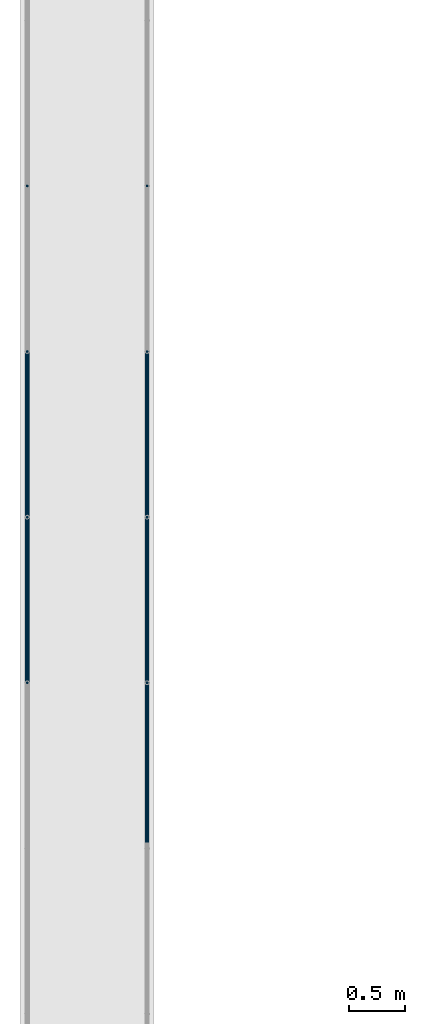
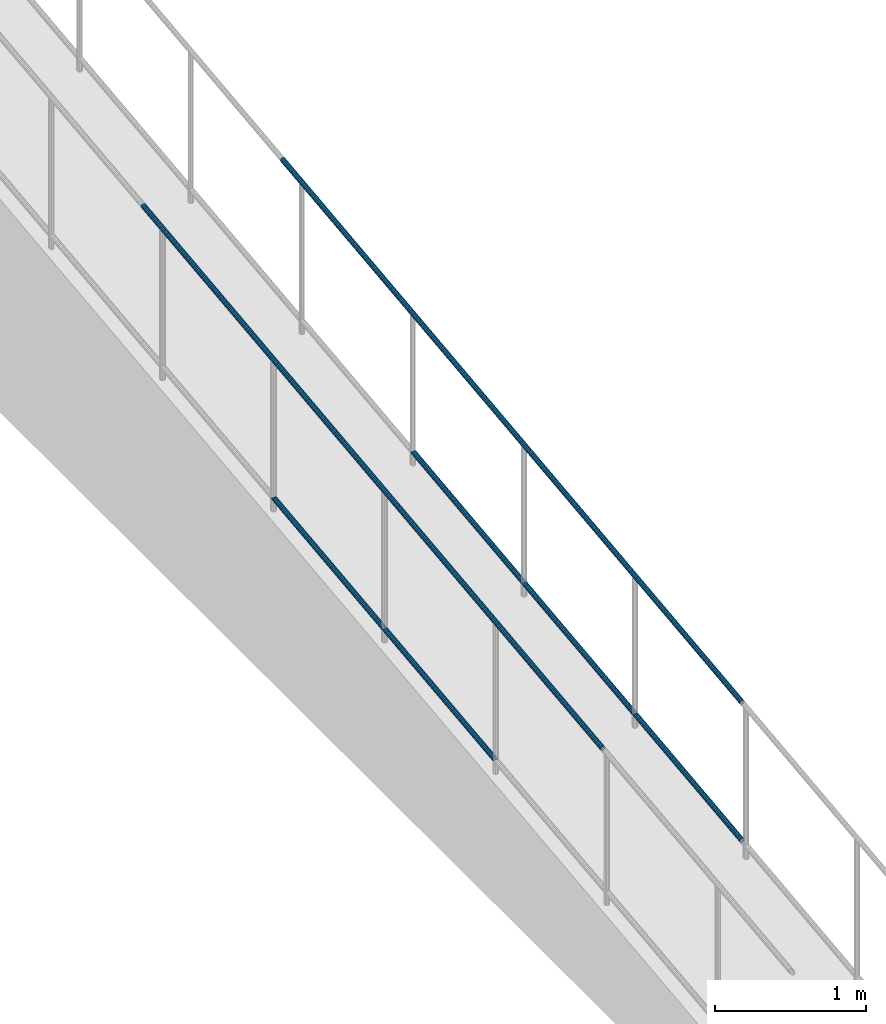
# One storey, part 1034 of 1763: 7 beams, 2 elements without a shape of their own.
"""IFC2X3 building model written with IfcOpenShell, lengths in millimetres."""

from ifc_helpers import new_model, si_unit, frame, origin_with_axes, place, context, subcontext, project, spatial, faceted_brep, material, type_object, element, aggregate, save


model = new_model("IFC2X3")

# Units and contexts
model_context = context("Model", 3, precision=1e-05, world=origin_with_axes())
body_context = subcontext(model_context, "Body", "Model", "MODEL_VIEW")
ifc_project = project(units=[si_unit("LENGTHUNIT", "METRE", prefix="MILLI"), si_unit("AREAUNIT", "SQUARE_METRE"), si_unit("VOLUMEUNIT", "CUBIC_METRE"), si_unit("MASSUNIT", "GRAM", prefix="KILO"), si_unit("TIMEUNIT", "SECOND"), si_unit("PLANEANGLEUNIT", "RADIAN"), si_unit("SOLIDANGLEUNIT", "STERADIAN"), si_unit("THERMODYNAMICTEMPERATUREUNIT", "DEGREE_CELSIUS"), si_unit("LUMINOUSINTENSITYUNIT", "LUMEN")], contexts=[model_context])

# Site, building, storey
site_placement = place(None, origin_with_axes())
site = spatial("IfcSite", under=ifc_project, at=site_placement, CompositionType="ELEMENT")
building_placement = place(site_placement, origin_with_axes())
building = spatial("IfcBuilding", under=site, at=building_placement, Name="Undefined", CompositionType="ELEMENT")
storey_placement = place(building_placement, origin_with_axes())
storey = spatial("IfcBuildingStorey", under=building, at=storey_placement, Name="Undefined", CompositionType="ELEMENT", Elevation=0.0)

# Assembly, beams
assembly_1_placement = place(storey_placement, origin_with_axes())
assembly_1 = element("IfcElementAssembly", 1, at=assembly_1_placement, inside=storey, Name="GUARDRAIL", AssemblyPlace="NOTDEFINED", PredefinedType="RIGID_FRAME")
ifc_material = material(Name="STEEL/A513")
beam_type = type_object("IfcBeamType", PredefinedType="NOTDEFINED")
beam_1_placement = place(assembly_1_placement, frame((-97200.6527017878, -5416.76211461858, 4661.28961246358), z_axis=(0.0, -0.114062593029902, 0.993473565260443), x_axis=(0.0, 0.993473565260443, 0.114062593029902)))
beam_1 = element("IfcBeam", 2, at=beam_1_placement, type_object=beam_type, material=ifc_material, Name="GUARDRAIL", context=body_context, shape_type="Brep", body=[
    faceted_brep([(1468.16665642951, -9.52499999999418, 16.4977839425555), (1467.58900470802, -9.52499999999418, 11.4667123804174), (1467.30376971339, -7.68349999999919, 13.3082123804179), (1465.46783960526, 0.0, 15.3670000004613), (1465.89071001447, 0.0, 19.0500000004622), (1467.3037697134, 7.68349999999919, 13.308212380417), (1467.58900470802, 9.52499999999418, 11.4667123804174), (1468.16665642951, 9.52499999999418, 16.4977839425555), (1482.87860532686, 19.0500000000029, 4.66570782009512e-10), (1474.38465767071, 16.4977839420899, 9.52500000046439), (1472.19739693342, 16.4977839420899, -9.52499999953761), (1470.96269582906, 13.3082123799541, 7.68350000046303), (1472.15281425492, 15.3669999999984, 4.6293280320242e-10), (1469.19830550098, 13.3082123799541, -7.68349999953807), (1464.95586142462, 9.52499999999418, -11.4667123794952), (1464.37820970313, 9.52499999999418, -16.4977839416342), (1464.24775602078, 7.68349999999919, -13.3082123794957), (1461.9390589491, 0.0, -15.3669999995409), (1461.51618853989, 0.0, -19.0499999995409), (1464.95586142462, -9.52499999999418, -11.4667123794952), (1464.37820970313, -9.52499999999418, -16.4977839416342), (1464.24775602078, -7.68349999999919, -13.3082123794948), (1482.87860532695, -19.0500000000029, 4.55656845588237e-10), (1472.19739693342, -16.4977839420899, -9.52499999953761), (1474.38465767071, -16.4977839420899, 9.52500000046439), (1469.19830550097, -13.3082123799541, -7.68349999953807), (1472.15281425491, -15.3669999999984, 4.6293280320242e-10), (1470.96269582905, -13.3082123799541, 7.68350000046303), (8.49463121237, -16.4977839420899, -9.52499999999782), (14.7126324911599, -9.52499999999418, -16.4977839420899), (0.00068350478454704, 19.0500000000029, 0.0), (8.49463121237, 16.4977839420899, -9.52499999999782), (10.6818918337324, 16.4977839420899, 9.52500000000418), (18.5010790167537, 9.52499999999418, 16.4977839421008), (21.3631001626848, 0.0, 19.0500000000075), (14.7126324911599, 9.52499999999418, -16.4977839420899), (16.9885789199607, 0.0, -19.0499999999956), (17.4114493067575, 0.0, -15.3669999999956), (15.2902841820321, -9.52499999999418, -11.4667123799509), (15.575519187561, -7.68349999999919, -13.3082123799513), (15.575519187561, 7.68349999999919, -13.3082123799513), (15.2902841820321, 9.52499999999418, -11.4667123799509), (11.9165930406441, 13.3082123799541, -7.68349999999646), (10.7264745694495, 15.3669999999984, 4.54747350886464e-12), (13.6809832752053, 13.3082123799541, 7.68350000000555), (17.923427325881, 9.52499999999418, 11.4667123799609), (18.631532718199, 7.68349999999919, 13.3082123799622), (20.9402297758882, 0.0, 15.3670000000075), (18.631532718199, -7.68349999999919, 13.3082123799622), (17.923427325881, -9.52499999999418, 11.4667123799609), (18.5010790167537, -9.52499999999418, 16.4977839421008), (10.6818918337324, -16.4977839420899, 9.52500000000418), (0.00068350478454704, -19.0500000000029, 0.0), (13.6809832752053, -13.3082123799541, 7.68350000000555), (10.7264745694495, -15.3669999999984, 4.54747350886464e-12), (11.9165930406441, -13.3082123799541, -7.68349999999646)], [[[0, 1, 2, 3, 4]], [[4, 3, 5, 6, 7]], [[8, 9, 10]], [[7, 6, 11, 12, 13, 14, 15, 10, 9]], [[16, 17, 18, 15, 14]], [[19, 20, 18, 17, 21]], [[22, 23, 24]], [[24, 23, 20, 19, 25, 26, 27, 1, 0]], [[28, 29, 20, 23]], [[30, 31, 32]], [[33, 34, 4, 7]], [[32, 33, 7, 9]], [[30, 32, 9, 8]], [[31, 30, 8, 10]], [[35, 31, 10, 15]], [[36, 35, 15, 18]], [[29, 36, 18, 20]], [[37, 36, 29, 38, 39]], [[40, 41, 35, 36, 37]], [[32, 31, 35, 41, 42, 43, 44, 45, 33]], [[33, 45, 46, 47, 34]], [[34, 47, 48, 49, 50]], [[34, 50, 0, 4]], [[50, 51, 24, 0]], [[51, 52, 22, 24]], [[52, 28, 23, 22]], [[51, 28, 52]], [[50, 49, 53, 54, 55, 38, 29, 28, 51]], [[55, 54, 26, 25]], [[21, 39, 38, 55, 25, 19]], [[37, 39, 21, 17]], [[40, 37, 17, 16]], [[42, 41, 40, 16, 14, 13]], [[43, 42, 13, 12]], [[44, 43, 12, 11]], [[5, 46, 45, 44, 11, 6]], [[47, 46, 5, 3]], [[48, 47, 3, 2]], [[53, 49, 48, 2, 1, 27]], [[54, 53, 27, 26]]]),
])
beam_2_placement = place(assembly_1_placement, frame((-97200.6527017878, -6889.96211609653, 4492.14871320254), z_axis=(0.0, -0.114062593029902, 0.993473565260443), x_axis=(0.0, 0.993473565260443, 0.114062593029902)))
beam_2 = element("IfcBeam", 3, at=beam_2_placement, type_object=beam_type, material=ifc_material, Name="GUARDRAIL", context=body_context, shape_type="Brep", body=[
    faceted_brep([(1468.16665642951, -9.52499999999418, 16.4977839425555), (1467.58900470802, -9.52499999999418, 11.4667123804174), (1467.30376971339, -7.68349999999919, 13.3082123804179), (1465.46783960526, 0.0, 15.3670000004613), (1465.89071001447, 0.0, 19.0500000004622), (1467.3037697134, 7.68349999999919, 13.308212380417), (1467.58900470802, 9.52499999999418, 11.4667123804174), (1468.16665642951, 9.52499999999418, 16.4977839425555), (1482.87860532686, 19.0500000000029, 4.66570782009512e-10), (1474.38465767071, 16.4977839420899, 9.52500000046439), (1472.19739693342, 16.4977839420899, -9.52499999953761), (1470.96269582906, 13.3082123799541, 7.68350000046303), (1472.15281425492, 15.3669999999984, 4.6293280320242e-10), (1469.19830550098, 13.3082123799541, -7.68349999953807), (1464.95586142462, 9.52499999999418, -11.4667123794952), (1464.37820970313, 9.52499999999418, -16.4977839416342), (1464.24775602078, 7.68349999999919, -13.3082123794957), (1461.9390589491, 0.0, -15.3669999995409), (1461.51618853989, 0.0, -19.0499999995409), (1464.95586142462, -9.52499999999418, -11.4667123794952), (1464.37820970313, -9.52499999999418, -16.4977839416342), (1464.24775602078, -7.68349999999919, -13.3082123794948), (1482.87860532695, -19.0500000000029, 4.55656845588237e-10), (1472.19739693342, -16.4977839420899, -9.52499999953761), (1474.38465767071, -16.4977839420899, 9.52500000046439), (1469.19830550097, -13.3082123799541, -7.68349999953807), (1472.15281425491, -15.3669999999984, 4.6293280320242e-10), (1470.96269582905, -13.3082123799541, 7.68350000046303), (8.49463121237, -16.4977839420899, -9.52499999999782), (14.7126324911599, -9.52499999999418, -16.4977839420899), (0.00068350478454704, 19.0500000000029, 0.0), (8.49463121237, 16.4977839420899, -9.52499999999782), (10.6818918337324, 16.4977839420899, 9.52500000000418), (18.5010790167537, 9.52499999999418, 16.4977839421008), (21.3631001626848, 0.0, 19.0500000000075), (14.7126324911599, 9.52499999999418, -16.4977839420899), (16.9885789199607, 0.0, -19.0499999999956), (17.4114493067575, 0.0, -15.3669999999956), (15.2902841820321, -9.52499999999418, -11.4667123799509), (15.575519187561, -7.68349999999919, -13.3082123799513), (15.575519187561, 7.68349999999919, -13.3082123799513), (15.2902841820321, 9.52499999999418, -11.4667123799509), (11.9165930406441, 13.3082123799541, -7.68349999999646), (10.7264745694495, 15.3669999999984, 4.54747350886464e-12), (13.6809832752053, 13.3082123799541, 7.68350000000555), (17.923427325881, 9.52499999999418, 11.4667123799609), (18.631532718199, 7.68349999999919, 13.3082123799622), (20.9402297758882, 0.0, 15.3670000000075), (18.631532718199, -7.68349999999919, 13.3082123799622), (17.923427325881, -9.52499999999418, 11.4667123799609), (18.5010790167537, -9.52499999999418, 16.4977839421008), (10.6818918337324, -16.4977839420899, 9.52500000000418), (0.00068350478454704, -19.0500000000029, 0.0), (13.6809832752053, -13.3082123799541, 7.68350000000555), (10.7264745694495, -15.3669999999984, 4.54747350886464e-12), (11.9165930406441, -13.3082123799541, -7.68349999999646)], [[[0, 1, 2, 3, 4]], [[4, 3, 5, 6, 7]], [[8, 9, 10]], [[7, 6, 11, 12, 13, 14, 15, 10, 9]], [[16, 17, 18, 15, 14]], [[19, 20, 18, 17, 21]], [[22, 23, 24]], [[24, 23, 20, 19, 25, 26, 27, 1, 0]], [[28, 29, 20, 23]], [[30, 31, 32]], [[33, 34, 4, 7]], [[32, 33, 7, 9]], [[30, 32, 9, 8]], [[31, 30, 8, 10]], [[35, 31, 10, 15]], [[36, 35, 15, 18]], [[29, 36, 18, 20]], [[37, 36, 29, 38, 39]], [[40, 41, 35, 36, 37]], [[32, 31, 35, 41, 42, 43, 44, 45, 33]], [[33, 45, 46, 47, 34]], [[34, 47, 48, 49, 50]], [[34, 50, 0, 4]], [[50, 51, 24, 0]], [[51, 52, 22, 24]], [[52, 28, 23, 22]], [[51, 28, 52]], [[50, 49, 53, 54, 55, 38, 29, 28, 51]], [[55, 54, 26, 25]], [[21, 39, 38, 55, 25, 19]], [[37, 39, 21, 17]], [[40, 37, 17, 16]], [[42, 41, 40, 16, 14, 13]], [[43, 42, 13, 12]], [[44, 43, 12, 11]], [[5, 46, 45, 44, 11, 6]], [[47, 46, 5, 3]], [[48, 47, 3, 2]], [[53, 49, 48, 2, 1, 27]], [[54, 53, 27, 26]]]),
])
beam_3_placement = place(assembly_1_placement, frame((-97200.6527017878, -2216.29390356327, 6146.34146606881), z_axis=(1.0, 0.0, 0.0), x_axis=(0.0, -0.993473565260443, -0.114062593029902)))
beam_3 = element("IfcBeam", 4, at=beam_3_placement, type_object=beam_type, material=ifc_material, Name="GUARDRAIL", context=body_context, shape_type="Brep", body=[
    faceted_brep([(4.71409293822944e-08, -15.3669999999984, 0.0), (-1.81898940354586e-12, -13.3082123799541, 7.68349999999919), (6136.046507088, -13.3082123818076, 7.68349999999919), (6136.046507088, -15.3670000018528, 0.0), (-3.63797880709171e-12, -7.68349999999919, 13.3082123799531), (6136.046507088, -7.68350000185274, 13.3082123799541), (-1.81898940354586e-12, 0.0, 15.3669999999966), (6136.046507088, -1.85082171810791e-09, 15.3669999999984), (-3.63797880709171e-12, 7.68349999999919, 13.3082123799531), (6136.046507088, 7.68349999814836, 13.3082123799541), (-1.81898940354586e-12, 13.3082123799541, 7.68349999999919), (6136.046507088, 13.3082123781051, 7.68349999999919), (4.71409293822944e-08, 15.3669999999984, 0.0), (6136.046507088, 15.3669999981494, 0.0), (3.63797880709171e-12, 13.3082123799541, -7.68349999999737), (6136.046507088, 13.3082123781051, -7.68349999999919), (3.63797880709171e-12, 7.68349999999919, -13.3082123799522), (6136.046507088, 7.68349999814836, -13.3082123799541), (3.63797880709171e-12, 0.0, -15.3669999999956), (6136.046507088, -1.85082171810791e-09, -15.3669999999984), (3.63797880709171e-12, -7.68349999999919, -13.3082123799522), (6136.046507088, -7.68350000185274, -13.3082123799541), (3.63797880709171e-12, -13.3082123799541, -7.68349999999737), (6136.046507088, -13.3082123818076, -7.68349999999919), (0.0, -19.0500000000029, 0.0), (0.0, -16.4977839420899, -9.52500000000146), (6136.046507088, -16.4977839439462, -9.52499999999418), (6136.046507088, -19.0500000018519, 0.0), (0.0, -9.52499999999418, -16.4977839420935), (6136.046507088, -9.52500000185228, -16.4977839420899), (1.45519152283669e-11, 1.81898940354586e-12, -19.0499999999993), (6136.046507088, -1.85082171810791e-09, -19.0500000000029), (0.0, 9.52499999999418, -16.4977839420935), (6136.046507088, 9.5249999981479, -16.4977839420899), (0.0, 16.4977839420899, -9.52500000000146), (6136.046507088, 16.4977839402427, -9.52499999999418), (0.0, 19.0500000000029, 0.0), (6136.046507088, 19.0499999981485, 0.0), (0.0, 16.4977839420899, 9.52500000000146), (6136.046507088, 16.4977839402427, 9.52499999999418), (0.0, 9.52499999999418, 16.4977839420935), (6136.046507088, 9.5249999981479, 16.4977839420899), (1.45519152283669e-11, 1.81898940354586e-12, 19.0499999999993), (6136.046507088, -1.85082171810791e-09, 19.0500000000029), (0.0, -9.52499999999418, 16.4977839420935), (6136.046507088, -9.52500000185228, 16.4977839420899), (0.0, -16.4977839420899, 9.52500000000146), (6136.046507088, -16.4977839439462, 9.52499999999418)], [[[0, 1, 2, 3]], [[1, 4, 5, 2]], [[4, 6, 7, 5]], [[6, 8, 9, 7]], [[8, 10, 11, 9]], [[10, 12, 13, 11]], [[12, 14, 15, 13]], [[14, 16, 17, 15]], [[16, 18, 19, 17]], [[18, 20, 21, 19]], [[20, 22, 23, 21]], [[22, 0, 3, 23]], [[24, 25, 26, 27]], [[25, 28, 29, 26]], [[28, 30, 31, 29]], [[30, 32, 33, 31]], [[32, 34, 35, 33]], [[34, 36, 37, 35]], [[36, 38, 39, 37]], [[38, 40, 41, 39]], [[40, 42, 43, 41]], [[42, 44, 45, 43]], [[44, 46, 47, 45]], [[46, 24, 27, 47]], [[29, 31, 33, 35, 37, 39, 41, 43, 45, 47, 27, 26], [5, 7, 9, 11, 13, 15, 17, 19, 21, 23, 3, 2]], [[46, 44, 42, 40, 38, 36, 34, 32, 30, 28, 25, 24], [22, 20, 18, 16, 14, 12, 10, 8, 6, 4, 1, 0]]]),
])
aggregate(assembly_1, [beam_1, beam_2, beam_3])

assembly_2_placement = place(storey_placement, origin_with_axes())
assembly_2 = element("IfcElementAssembly", 5, at=assembly_2_placement, inside=storey, Name="GUARDRAIL", AssemblyPlace="NOTDEFINED", PredefinedType="RIGID_FRAME")
beam_4_placement = place(assembly_2_placement, frame((-96133.8527017878, -2216.29390356327, 6146.34146606881), z_axis=(1.0, 0.0, 0.0), x_axis=(0.0, -0.993473565260443, -0.114062593029902)))
beam_4 = element("IfcBeam", 6, at=beam_4_placement, type_object=beam_type, material=ifc_material, Name="GUARDRAIL", context=body_context, shape_type="Brep", body=[
    faceted_brep([(4.71409293822944e-08, -15.3669999999984, 0.0), (-1.81898940354586e-12, -13.3082123799541, 7.68349999999919), (6136.046507088, -13.3082123818076, 7.68349999999919), (6136.046507088, -15.3670000018528, 0.0), (-3.63797880709171e-12, -7.68349999999919, 13.3082123799531), (6136.046507088, -7.68350000185274, 13.3082123799541), (-1.81898940354586e-12, 0.0, 15.3669999999966), (6136.046507088, -1.85082171810791e-09, 15.3669999999984), (-3.63797880709171e-12, 7.68349999999919, 13.3082123799531), (6136.046507088, 7.68349999814836, 13.3082123799541), (-1.81898940354586e-12, 13.3082123799541, 7.68349999999919), (6136.046507088, 13.3082123781051, 7.68349999999919), (4.71409293822944e-08, 15.3669999999984, 0.0), (6136.046507088, 15.3669999981494, 0.0), (3.63797880709171e-12, 13.3082123799541, -7.68349999999737), (6136.046507088, 13.3082123781051, -7.68349999999919), (3.63797880709171e-12, 7.68349999999919, -13.3082123799522), (6136.046507088, 7.68349999814836, -13.3082123799541), (3.63797880709171e-12, 0.0, -15.3669999999956), (6136.046507088, -1.85082171810791e-09, -15.3669999999984), (3.63797880709171e-12, -7.68349999999919, -13.3082123799522), (6136.046507088, -7.68350000185274, -13.3082123799541), (3.63797880709171e-12, -13.3082123799541, -7.68349999999737), (6136.046507088, -13.3082123818076, -7.68349999999919), (0.0, -19.0500000000029, 0.0), (0.0, -16.4977839420899, -9.52500000000146), (6136.046507088, -16.4977839439462, -9.52499999999418), (6136.046507088, -19.0500000018519, 0.0), (0.0, -9.52499999999418, -16.4977839420935), (6136.046507088, -9.52500000185228, -16.4977839420899), (1.45519152283669e-11, 1.81898940354586e-12, -19.0499999999993), (6136.046507088, -1.85082171810791e-09, -19.0500000000029), (0.0, 9.52499999999418, -16.4977839420935), (6136.046507088, 9.5249999981479, -16.4977839420899), (0.0, 16.4977839420899, -9.52500000000146), (6136.046507088, 16.4977839402427, -9.52499999999418), (0.0, 19.0500000000029, 0.0), (6136.046507088, 19.0499999981485, 0.0), (0.0, 16.4977839420899, 9.52500000000146), (6136.046507088, 16.4977839402427, 9.52499999999418), (0.0, 9.52499999999418, 16.4977839420935), (6136.046507088, 9.5249999981479, 16.4977839420899), (1.45519152283669e-11, 1.81898940354586e-12, 19.0499999999993), (6136.046507088, -1.85082171810791e-09, 19.0500000000029), (0.0, -9.52499999999418, 16.4977839420935), (6136.046507088, -9.52500000185228, 16.4977839420899), (0.0, -16.4977839420899, 9.52500000000146), (6136.046507088, -16.4977839439462, 9.52499999999418)], [[[0, 1, 2, 3]], [[1, 4, 5, 2]], [[4, 6, 7, 5]], [[6, 8, 9, 7]], [[8, 10, 11, 9]], [[10, 12, 13, 11]], [[12, 14, 15, 13]], [[14, 16, 17, 15]], [[16, 18, 19, 17]], [[18, 20, 21, 19]], [[20, 22, 23, 21]], [[22, 0, 3, 23]], [[24, 25, 26, 27]], [[25, 28, 29, 26]], [[28, 30, 31, 29]], [[30, 32, 33, 31]], [[32, 34, 35, 33]], [[34, 36, 37, 35]], [[36, 38, 39, 37]], [[38, 40, 41, 39]], [[40, 42, 43, 41]], [[42, 44, 45, 43]], [[44, 46, 47, 45]], [[46, 24, 27, 47]], [[29, 31, 33, 35, 37, 39, 41, 43, 45, 47, 27, 26], [5, 7, 9, 11, 13, 15, 17, 19, 21, 23, 3, 2]], [[46, 44, 42, 40, 38, 36, 34, 32, 30, 28, 25, 24], [22, 20, 18, 16, 14, 12, 10, 8, 6, 4, 1, 0]]]),
])
beam_5_placement = place(assembly_2_placement, frame((-96133.8527017878, -8312.29390356087, 4328.84809050872), z_axis=(0.0, -0.114062593029902, 0.993473565260443), x_axis=(0.0, 0.993473565260443, 0.114062593029902)))
beam_5 = element("IfcBeam", 7, at=beam_5_placement, type_object=beam_type, material=ifc_material, Name="GUARDRAIL", context=body_context, shape_type="Brep", body=[
    faceted_brep([(1416.96425795379, -9.52499999999418, 16.497783942521), (1416.3866062935, -9.52499999999418, 11.4667123803829), (1416.10137127725, -7.68349999999919, 13.3082123803824), (1414.26544114684, 0.0, 15.3670000004267), (1414.68831151125, 0.0, 19.0500000004258), (1416.10137127725, 7.68349999999919, 13.3082123803824), (1416.3866062935, 9.52499999999418, 11.4667123803829), (1416.96425795379, 9.52499999999418, 16.497783942521), (1431.67620549499, 19.0500000000029, 4.32009983342141e-10), (1423.18225927013, 16.4977839420899, 9.52500000042892), (1420.99499876456, 16.4977839420899, -9.52499999957126), (1419.7602974554, 13.3082123799541, 7.68350000042756), (1420.95041597187, 15.3669999999984, 4.29281499236822e-10), (1417.99590731425, 13.3082123799541, -7.68349999957263), (1413.75346328905, 9.52499999999418, -11.4667123795289), (1413.17581162876, 9.52499999999418, -16.4977839416679), (1413.04535790842, 7.68349999999919, -13.3082123795293), (1410.73666086452, 0.0, -15.3669999995745), (1410.31379050011, 0.0, -19.0499999995736), (1413.75346328905, -9.52499999999418, -11.4667123795289), (1413.17581162876, -9.52499999999418, -16.4977839416679), (1413.04535790842, -7.68349999999919, -13.3082123795293), (1431.67620700905, -19.0500000000029, -1.73407897818834e-07), (1420.99499876456, -16.4977839420899, -9.52499999957126), (1423.18225927013, -16.4977839420899, 9.52500000042892), (1417.99590731425, -13.3082123799541, -7.68349999957263), (1420.95041597187, -15.3669999999984, 4.29281499236822e-10), (1419.7602974554, -13.3082123799541, 7.68350000042756), (0.0, -16.4977839420899, -9.52500000000146), (0.0, -9.52499999999418, -16.4977839420935), (1.45519152283669e-11, 1.81898940354586e-12, -19.0499999999993), (0.0, 9.52499999999418, -16.4977839420935), (0.0, 16.4977839420899, -9.52500000000146), (0.0, 19.0500000000029, 0.0), (0.0, 16.4977839420899, 9.52500000000146), (0.0, 9.52499999999418, 16.4977839420935), (1.45519152283669e-11, 1.81898940354586e-12, 19.0499999999993), (0.0, -9.52499999999418, 16.4977839420935), (0.0, -16.4977839420899, 9.52500000000146), (0.0, -19.0500000000029, 0.0), (3.63797880709171e-12, -13.3082123799541, -7.68349999999737), (3.63797880709171e-12, -7.68349999999919, -13.3082123799522), (3.63797880709171e-12, 0.0, -15.3669999999956), (3.63797880709171e-12, 7.68349999999919, -13.3082123799522), (3.63797880709171e-12, 13.3082123799541, -7.68349999999737), (4.71409293822944e-08, 15.3669999999984, 0.0), (-1.81898940354586e-12, 13.3082123799541, 7.68349999999919), (-3.63797880709171e-12, 7.68349999999919, 13.3082123799531), (-1.81898940354586e-12, 0.0, 15.3669999999966), (-3.63797880709171e-12, -7.68349999999919, 13.3082123799531), (-1.81898940354586e-12, -13.3082123799541, 7.68349999999919), (4.71409293822944e-08, -15.3669999999984, 0.0)], [[[0, 1, 2, 3, 4]], [[4, 3, 5, 6, 7]], [[8, 9, 10]], [[7, 6, 11, 12, 13, 14, 15, 10, 9]], [[16, 17, 18, 15, 14]], [[19, 20, 18, 17, 21]], [[22, 23, 24]], [[24, 23, 20, 19, 25, 26, 27, 1, 0]], [[28, 29, 20, 23]], [[29, 30, 18, 20]], [[30, 31, 15, 18]], [[31, 32, 10, 15]], [[32, 33, 8, 10]], [[33, 34, 9, 8]], [[34, 35, 7, 9]], [[35, 36, 4, 7]], [[36, 37, 0, 4]], [[37, 38, 24, 0]], [[38, 39, 22, 24]], [[39, 28, 23, 22]], [[38, 37, 36, 35, 34, 33, 32, 31, 30, 29, 28, 39], [40, 41, 42, 43, 44, 45, 46, 47, 48, 49, 50, 51]], [[40, 51, 26, 25]], [[21, 41, 40, 25, 19]], [[42, 41, 21, 17]], [[43, 42, 17, 16]], [[44, 43, 16, 14, 13]], [[45, 44, 13, 12]], [[46, 45, 12, 11]], [[5, 47, 46, 11, 6]], [[48, 47, 5, 3]], [[49, 48, 3, 2]], [[50, 49, 2, 1, 27]], [[51, 50, 27, 26]]]),
])
beam_6_placement = place(assembly_2_placement, frame((-96133.8527017878, -5416.76211461858, 4661.28961246358), z_axis=(0.0, -0.114062593029902, 0.993473565260443), x_axis=(0.0, 0.993473565260443, 0.114062593029902)))
beam_6 = element("IfcBeam", 8, at=beam_6_placement, type_object=beam_type, material=ifc_material, Name="GUARDRAIL", context=body_context, shape_type="Brep", body=[
    faceted_brep([(1468.16665642951, -9.52499999999418, 16.4977839425555), (1467.58900470802, -9.52499999999418, 11.4667123804174), (1467.30376971339, -7.68349999999919, 13.3082123804179), (1465.46783960526, 0.0, 15.3670000004613), (1465.89071001447, 0.0, 19.0500000004622), (1467.3037697134, 7.68349999999919, 13.308212380417), (1467.58900470802, 9.52499999999418, 11.4667123804174), (1468.16665642951, 9.52499999999418, 16.4977839425555), (1482.87860532686, 19.0500000000029, 4.66570782009512e-10), (1474.38465767071, 16.4977839420899, 9.52500000046439), (1472.19739693342, 16.4977839420899, -9.52499999953761), (1470.96269582906, 13.3082123799541, 7.68350000046303), (1472.15281425492, 15.3669999999984, 4.6293280320242e-10), (1469.19830550098, 13.3082123799541, -7.68349999953807), (1464.95586142462, 9.52499999999418, -11.4667123794952), (1464.37820970313, 9.52499999999418, -16.4977839416342), (1464.24775602078, 7.68349999999919, -13.3082123794957), (1461.9390589491, 0.0, -15.3669999995409), (1461.51618853989, 0.0, -19.0499999995409), (1464.95586142462, -9.52499999999418, -11.4667123794952), (1464.37820970313, -9.52499999999418, -16.4977839416342), (1464.24775602078, -7.68349999999919, -13.3082123794948), (1482.87860532695, -19.0500000000029, 4.55656845588237e-10), (1472.19739693342, -16.4977839420899, -9.52499999953761), (1474.38465767071, -16.4977839420899, 9.52500000046439), (1469.19830550097, -13.3082123799541, -7.68349999953807), (1472.15281425491, -15.3669999999984, 4.6293280320242e-10), (1470.96269582905, -13.3082123799541, 7.68350000046303), (8.49463121237, -16.4977839420899, -9.52499999999782), (14.7126324911599, -9.52499999999418, -16.4977839420899), (0.00068350478454704, 19.0500000000029, 0.0), (8.49463121237, 16.4977839420899, -9.52499999999782), (10.6818918337324, 16.4977839420899, 9.52500000000418), (18.5010790167537, 9.52499999999418, 16.4977839421008), (21.3631001626848, 0.0, 19.0500000000075), (14.7126324911599, 9.52499999999418, -16.4977839420899), (16.9885789199607, 0.0, -19.0499999999956), (17.4114493067575, 0.0, -15.3669999999956), (15.2902841820321, -9.52499999999418, -11.4667123799509), (15.575519187561, -7.68349999999919, -13.3082123799513), (15.575519187561, 7.68349999999919, -13.3082123799513), (15.2902841820321, 9.52499999999418, -11.4667123799509), (11.9165930406441, 13.3082123799541, -7.68349999999646), (10.7264745694495, 15.3669999999984, 4.54747350886464e-12), (13.6809832752053, 13.3082123799541, 7.68350000000555), (17.923427325881, 9.52499999999418, 11.4667123799609), (18.631532718199, 7.68349999999919, 13.3082123799622), (20.9402297758882, 0.0, 15.3670000000075), (18.631532718199, -7.68349999999919, 13.3082123799622), (17.923427325881, -9.52499999999418, 11.4667123799609), (18.5010790167537, -9.52499999999418, 16.4977839421008), (10.6818918337324, -16.4977839420899, 9.52500000000418), (0.00068350478454704, -19.0500000000029, 0.0), (13.6809832752053, -13.3082123799541, 7.68350000000555), (10.7264745694495, -15.3669999999984, 4.54747350886464e-12), (11.9165930406441, -13.3082123799541, -7.68349999999646)], [[[0, 1, 2, 3, 4]], [[4, 3, 5, 6, 7]], [[8, 9, 10]], [[7, 6, 11, 12, 13, 14, 15, 10, 9]], [[16, 17, 18, 15, 14]], [[19, 20, 18, 17, 21]], [[22, 23, 24]], [[24, 23, 20, 19, 25, 26, 27, 1, 0]], [[28, 29, 20, 23]], [[30, 31, 32]], [[33, 34, 4, 7]], [[32, 33, 7, 9]], [[30, 32, 9, 8]], [[31, 30, 8, 10]], [[35, 31, 10, 15]], [[36, 35, 15, 18]], [[29, 36, 18, 20]], [[37, 36, 29, 38, 39]], [[40, 41, 35, 36, 37]], [[32, 31, 35, 41, 42, 43, 44, 45, 33]], [[33, 45, 46, 47, 34]], [[34, 47, 48, 49, 50]], [[34, 50, 0, 4]], [[50, 51, 24, 0]], [[51, 52, 22, 24]], [[52, 28, 23, 22]], [[51, 28, 52]], [[50, 49, 53, 54, 55, 38, 29, 28, 51]], [[55, 54, 26, 25]], [[21, 39, 38, 55, 25, 19]], [[37, 39, 21, 17]], [[40, 37, 17, 16]], [[42, 41, 40, 16, 14, 13]], [[43, 42, 13, 12]], [[44, 43, 12, 11]], [[5, 46, 45, 44, 11, 6]], [[47, 46, 5, 3]], [[48, 47, 3, 2]], [[53, 49, 48, 2, 1, 27]], [[54, 53, 27, 26]]]),
])
beam_7_placement = place(assembly_2_placement, frame((-96133.8527017878, -6889.96211609653, 4492.14871320254), z_axis=(0.0, -0.114062593029902, 0.993473565260443), x_axis=(0.0, 0.993473565260443, 0.114062593029902)))
beam_7 = element("IfcBeam", 9, at=beam_7_placement, type_object=beam_type, material=ifc_material, Name="GUARDRAIL", context=body_context, shape_type="Brep", body=[
    faceted_brep([(1468.16665642951, -9.52499999999418, 16.4977839425555), (1467.58900470802, -9.52499999999418, 11.4667123804174), (1467.30376971339, -7.68349999999919, 13.3082123804179), (1465.46783960526, 0.0, 15.3670000004613), (1465.89071001447, 0.0, 19.0500000004622), (1467.3037697134, 7.68349999999919, 13.308212380417), (1467.58900470802, 9.52499999999418, 11.4667123804174), (1468.16665642951, 9.52499999999418, 16.4977839425555), (1482.87860532686, 19.0500000000029, 4.66570782009512e-10), (1474.38465767071, 16.4977839420899, 9.52500000046439), (1472.19739693342, 16.4977839420899, -9.52499999953761), (1470.96269582906, 13.3082123799541, 7.68350000046303), (1472.15281425492, 15.3669999999984, 4.6293280320242e-10), (1469.19830550098, 13.3082123799541, -7.68349999953807), (1464.95586142462, 9.52499999999418, -11.4667123794952), (1464.37820970313, 9.52499999999418, -16.4977839416342), (1464.24775602078, 7.68349999999919, -13.3082123794957), (1461.9390589491, 0.0, -15.3669999995409), (1461.51618853989, 0.0, -19.0499999995409), (1464.95586142462, -9.52499999999418, -11.4667123794952), (1464.37820970313, -9.52499999999418, -16.4977839416342), (1464.24775602078, -7.68349999999919, -13.3082123794948), (1482.87860532695, -19.0500000000029, 4.55656845588237e-10), (1472.19739693342, -16.4977839420899, -9.52499999953761), (1474.38465767071, -16.4977839420899, 9.52500000046439), (1469.19830550097, -13.3082123799541, -7.68349999953807), (1472.15281425491, -15.3669999999984, 4.6293280320242e-10), (1470.96269582905, -13.3082123799541, 7.68350000046303), (8.49463121237, -16.4977839420899, -9.52499999999782), (14.7126324911599, -9.52499999999418, -16.4977839420899), (0.00068350478454704, 19.0500000000029, 0.0), (8.49463121237, 16.4977839420899, -9.52499999999782), (10.6818918337324, 16.4977839420899, 9.52500000000418), (18.5010790167537, 9.52499999999418, 16.4977839421008), (21.3631001626848, 0.0, 19.0500000000075), (14.7126324911599, 9.52499999999418, -16.4977839420899), (16.9885789199607, 0.0, -19.0499999999956), (17.4114493067575, 0.0, -15.3669999999956), (15.2902841820321, -9.52499999999418, -11.4667123799509), (15.575519187561, -7.68349999999919, -13.3082123799513), (15.575519187561, 7.68349999999919, -13.3082123799513), (15.2902841820321, 9.52499999999418, -11.4667123799509), (11.9165930406441, 13.3082123799541, -7.68349999999646), (10.7264745694495, 15.3669999999984, 4.54747350886464e-12), (13.6809832752053, 13.3082123799541, 7.68350000000555), (17.923427325881, 9.52499999999418, 11.4667123799609), (18.631532718199, 7.68349999999919, 13.3082123799622), (20.9402297758882, 0.0, 15.3670000000075), (18.631532718199, -7.68349999999919, 13.3082123799622), (17.923427325881, -9.52499999999418, 11.4667123799609), (18.5010790167537, -9.52499999999418, 16.4977839421008), (10.6818918337324, -16.4977839420899, 9.52500000000418), (0.00068350478454704, -19.0500000000029, 0.0), (13.6809832752053, -13.3082123799541, 7.68350000000555), (10.7264745694495, -15.3669999999984, 4.54747350886464e-12), (11.9165930406441, -13.3082123799541, -7.68349999999646)], [[[0, 1, 2, 3, 4]], [[4, 3, 5, 6, 7]], [[8, 9, 10]], [[7, 6, 11, 12, 13, 14, 15, 10, 9]], [[16, 17, 18, 15, 14]], [[19, 20, 18, 17, 21]], [[22, 23, 24]], [[24, 23, 20, 19, 25, 26, 27, 1, 0]], [[28, 29, 20, 23]], [[30, 31, 32]], [[33, 34, 4, 7]], [[32, 33, 7, 9]], [[30, 32, 9, 8]], [[31, 30, 8, 10]], [[35, 31, 10, 15]], [[36, 35, 15, 18]], [[29, 36, 18, 20]], [[37, 36, 29, 38, 39]], [[40, 41, 35, 36, 37]], [[32, 31, 35, 41, 42, 43, 44, 45, 33]], [[33, 45, 46, 47, 34]], [[34, 47, 48, 49, 50]], [[34, 50, 0, 4]], [[50, 51, 24, 0]], [[51, 52, 22, 24]], [[52, 28, 23, 22]], [[51, 28, 52]], [[50, 49, 53, 54, 55, 38, 29, 28, 51]], [[55, 54, 26, 25]], [[21, 39, 38, 55, 25, 19]], [[37, 39, 21, 17]], [[40, 37, 17, 16]], [[42, 41, 40, 16, 14, 13]], [[43, 42, 13, 12]], [[44, 43, 12, 11]], [[5, 46, 45, 44, 11, 6]], [[47, 46, 5, 3]], [[48, 47, 3, 2]], [[53, 49, 48, 2, 1, 27]], [[54, 53, 27, 26]]]),
])
aggregate(assembly_2, [beam_4, beam_5, beam_6, beam_7])

save(model, "model.ifc")
